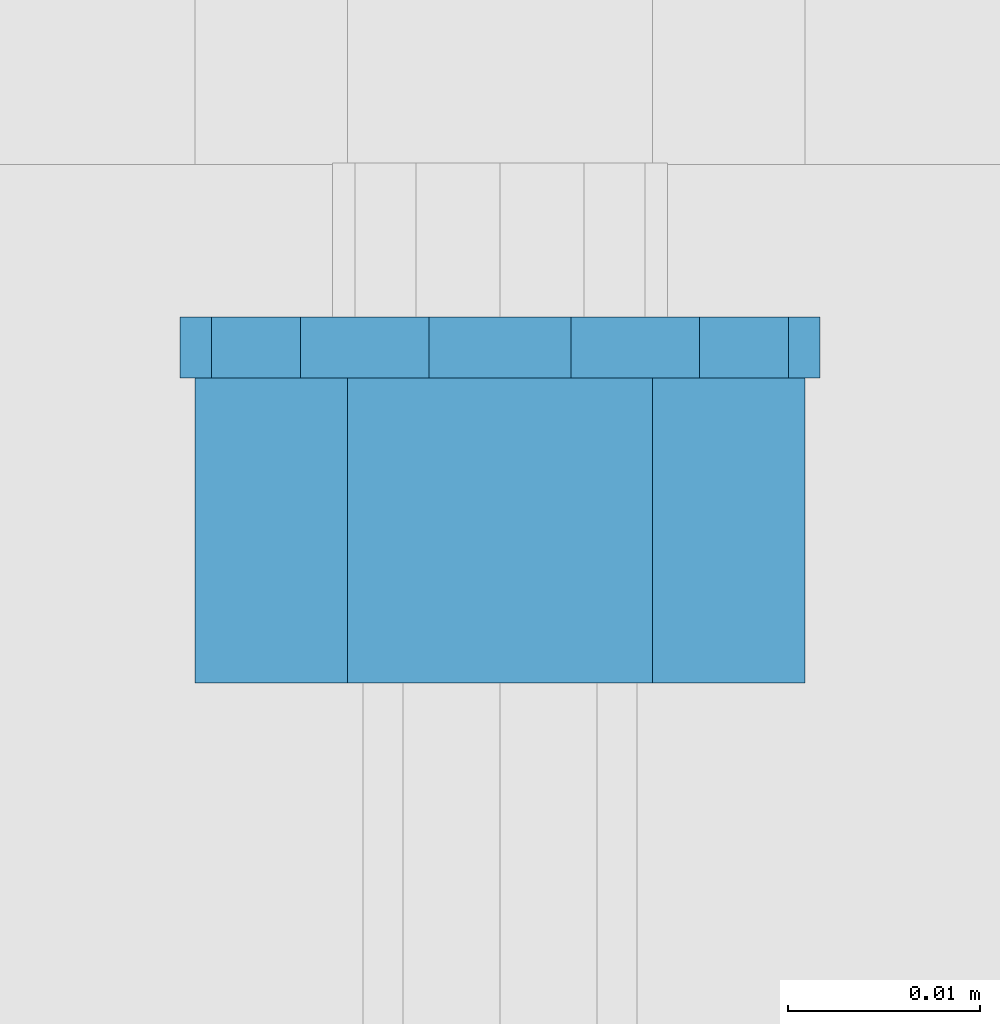
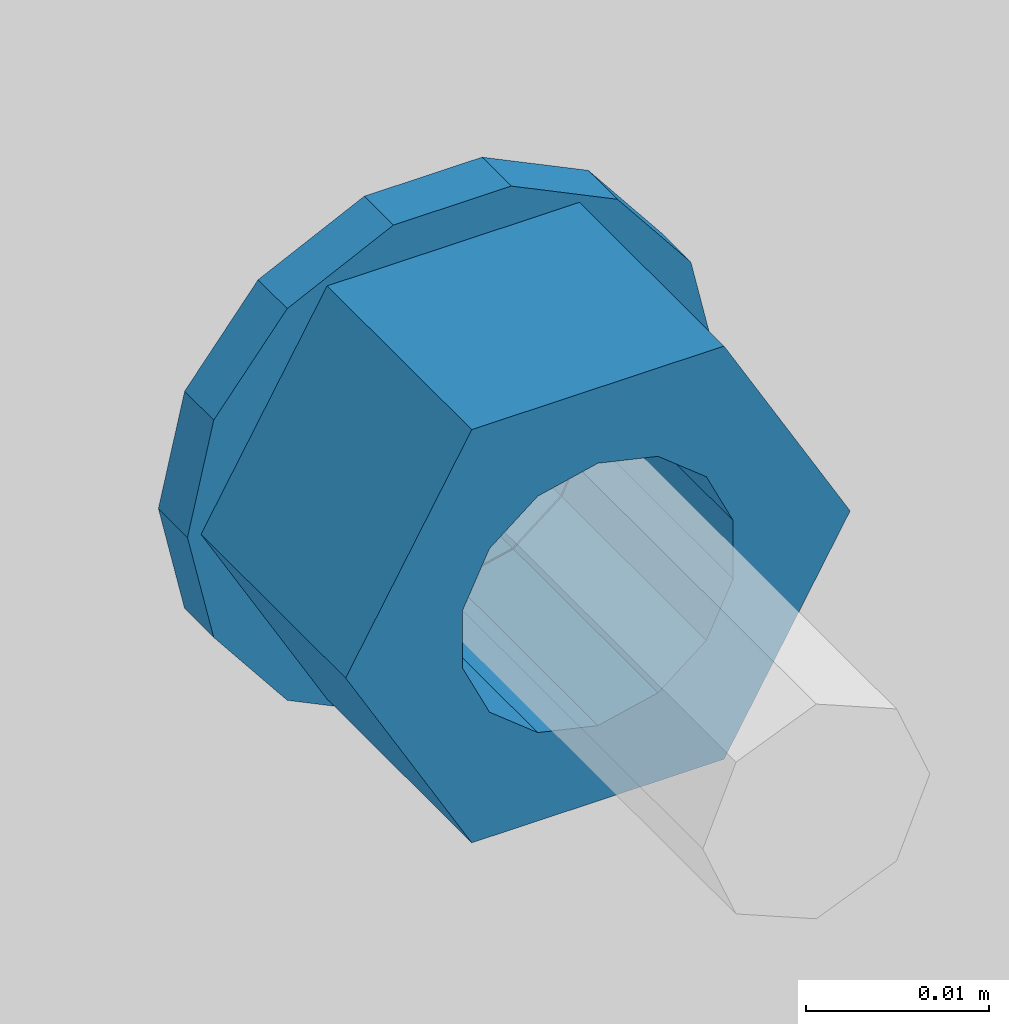
# One storey, part 613 of 975: 2 beams.
"""IFC2X3 building model written with IfcOpenShell, lengths in millimetres."""

from ifc_helpers import new_model, si_unit, frame, origin_with_axes, place, context, subcontext, project, spatial, faceted_brep, material, type_object, element, save


model = new_model("IFC2X3")

# Units and contexts
model_context = context("Model", 3, precision=1e-05, world=origin_with_axes())
body_context = subcontext(model_context, "Body", "Model", "MODEL_VIEW")
ifc_project = project(units=[si_unit("LENGTHUNIT", "METRE", prefix="MILLI"), si_unit("AREAUNIT", "SQUARE_METRE"), si_unit("VOLUMEUNIT", "CUBIC_METRE"), si_unit("MASSUNIT", "GRAM", prefix="KILO"), si_unit("TIMEUNIT", "SECOND"), si_unit("PLANEANGLEUNIT", "RADIAN"), si_unit("SOLIDANGLEUNIT", "STERADIAN"), si_unit("THERMODYNAMICTEMPERATUREUNIT", "DEGREE_CELSIUS"), si_unit("LUMINOUSINTENSITYUNIT", "LUMEN")], contexts=[model_context])

# Site, building, storey
site_placement = place(None, origin_with_axes())
site = spatial("IfcSite", under=ifc_project, at=site_placement, CompositionType="ELEMENT")
building_placement = place(site_placement, origin_with_axes())
building = spatial("IfcBuilding", under=site, at=building_placement, Name="Undefined", CompositionType="ELEMENT")
storey_placement = place(building_placement, origin_with_axes())
storey = spatial("IfcBuildingStorey", under=building, at=storey_placement, Name="Undefined", CompositionType="ELEMENT", Elevation=0.0)

# Beams
ifc_material = material(Name="STEEL/A36")
beam_type_1 = type_object("IfcBeamType", Name="5/8_HEAVY_HEX_NUT", PredefinedType="NOTDEFINED")
beam_1_placement = place(storey_placement, frame((9848.84992675423, 20416.8375, 3886.2), z_axis=(0.0, 0.0, 1.0), x_axis=(0.0, 1.0, 0.0)))
element("IfcBeam", 1, at=beam_1_placement, inside=storey, type_object=beam_type_1, material=ifc_material, Name="NUT", ObjectType="5/8_HEAVY_HEX_NUT", context=body_context, shape_type="Brep", body=[
    faceted_brep([(-1.09139364212751e-11, -15.8800001144436, -2.72848410531878e-12), (1.45519152283669e-11, -7.94000005722046, -13.7500000000036), (15.8750000000146, -7.94000005722137, -13.7500000000045), (15.8749999999891, -15.8800001144446, -2.72848410531878e-12), (2.91038304567337e-11, 7.94000005722319, -13.7500000000027), (15.8750000000291, 7.94000005722319, -13.7500000000027), (2.18278728425503e-11, 15.8800001144436, 9.09494701772928e-13), (15.8750000000218, 15.8800001144427, 9.09494701772928e-13), (-7.27595761418343e-12, 7.94000005722046, 13.7500000000027), (15.8749999999927, 7.94000005722046, 13.7500000000027), (-2.18278728425503e-11, -7.94000005722228, 13.7500000000009), (15.8749999999782, -7.94000005722319, 13.7500000000009), (-7.27595761418343e-12, 0.0, 8.72999954223724), (0.0, 3.78780484388062, 7.86545780435881), (15.875, 3.78780484387971, 7.86545780435881), (15.8749999999927, -9.09494701772928e-13, 8.72999954223724), (7.27595761418343e-12, 6.82538848405238, 5.44306568481716), (15.8750000000073, 6.82538848405238, 5.44306568481716), (1.09139364212751e-11, 8.51112022706275, 1.94260765157742), (15.8750000000109, 8.51112022706093, 1.94260765157651), (1.45519152283669e-11, 8.51112022706184, -1.94260765157651), (15.8750000000146, 8.51112022706184, -1.94260765157651), (2.18278728425503e-11, 6.8253884840542, -5.44306568481716), (15.8750000000218, 6.82538848405238, -5.44306568481716), (1.81898940354586e-11, 3.78780484388153, -7.86545780435881), (15.8750000000182, 3.78780484388062, -7.86545780435881), (1.81898940354586e-11, 9.09494701772928e-13, -8.72999954223997), (15.8750000000182, 9.09494701772928e-13, -8.72999954223997), (1.09139364212751e-11, -3.78780484387971, -7.86545780436063), (15.8750000000109, -3.78780484388062, -7.86545780436063), (3.63797880709171e-12, -6.82538848405238, -5.44306568481807), (15.8750000000036, -6.82538848405329, -5.44306568481807), (0.0, -8.51112022706184, -1.94260765157833), (15.875, -8.51112022706184, -1.94260765157833), (-7.27595761418343e-12, -8.51112022706184, 1.9426076515756), (15.8749999999927, -8.51112022706275, 1.9426076515756), (-1.09139364212751e-11, -6.82538848405329, 5.44306568481534), (15.8749999999927, -6.8253884840542, 5.44306568481534), (-7.27595761418343e-12, -3.78780484388062, 7.8654578043579), (15.8749999999927, -3.78780484388153, 7.8654578043579)], [[[0, 1, 2, 3]], [[1, 4, 5, 2]], [[4, 6, 7, 5]], [[6, 8, 9, 7]], [[8, 10, 11, 9]], [[10, 0, 3, 11]], [[12, 13, 14, 15]], [[13, 16, 17, 14]], [[16, 18, 19, 17]], [[18, 20, 21, 19]], [[20, 22, 23, 21]], [[22, 24, 25, 23]], [[24, 26, 27, 25]], [[26, 28, 29, 27]], [[28, 30, 31, 29]], [[30, 32, 33, 31]], [[32, 34, 35, 33]], [[34, 36, 37, 35]], [[36, 38, 39, 37]], [[38, 12, 15, 39]], [[5, 7, 9, 11, 3, 2], [17, 19, 21, 23, 25, 27, 29, 31, 33, 35, 37, 39, 15, 14]], [[10, 8, 6, 4, 1, 0], [38, 36, 34, 32, 30, 28, 26, 24, 22, 20, 18, 16, 13, 12]]]),
])
beam_type_2 = type_object("IfcBeamType", Name="5/8_WASHER", PredefinedType="NOTDEFINED")
beam_2_placement = place(storey_placement, frame((9848.84992675424, 20432.7125, 3886.2), z_axis=(0.0, 0.0, 1.0), x_axis=(0.0, 1.0, 0.0)))
element("IfcBeam", 2, at=beam_2_placement, inside=storey, type_object=beam_type_2, material=ifc_material, Name="WASHER", ObjectType="5/8_WASHER", context=body_context, shape_type="Brep", body=[
    faceted_brep([(1.09139364212751e-11, -16.670000076293, -2.72848410531878e-12), (2.18278728425503e-11, -15.0191510966704, -7.23284196419536), (3.1750000000211, -15.0191510966711, -7.23284196419627), (3.17500000001019, -16.6700000762937, -1.81898940354586e-12), (2.91038304567337e-11, -10.3935750445523, -13.0331308723944), (3.17500000002838, -10.3935750445526, -13.0331308723953), (2.91038304567337e-11, -3.70942398602756, -16.2520483704566), (3.17500000002838, -3.70942398602779, -16.2520483704566), (2.5465851649642e-11, 3.70942398602961, -16.2520483704557), (3.17500000002474, 3.70942398602961, -16.2520483704566), (1.45519152283669e-11, 10.3935750445542, -13.0331308723935), (3.17500000001382, 10.3935750445537, -13.0331308723944), (0.0, 15.0191510966717, -7.23284196419354), (3.17499999999927, 15.0191510966713, -7.23284196419354), (-7.27595761418343e-12, 16.6700000762933, 0.0), (3.174999999992, 16.6700000762928, -9.09494701772928e-13), (-1.81898940354586e-11, 15.0191510966706, 7.23284196419354), (3.17499999998108, 15.0191510966704, 7.23284196419354), (-2.5465851649642e-11, 10.3935750445519, 13.0331308723926), (3.17499999997381, 10.3935750445517, 13.0331308723926), (-2.5465851649642e-11, 3.70942398602733, 16.2520483704538), (3.17499999997381, 3.7094239860271, 16.2520483704529), (-2.18278728425503e-11, -3.70942398602983, 16.2520483704529), (3.17499999997744, -3.70942398603006, 16.2520483704538), (-1.09139364212751e-11, -10.3935750445542, 13.0331308723908), (3.17499999998836, -10.3935750445544, 13.0331308723908), (0.0, -15.0191510966717, 7.23284196419172), (3.17499999999927, -15.019151096672, 7.23284196419081), (-7.27595761418343e-12, 0.0, 8.72999954223724), (0.0, 3.78780484388062, 7.86545780435881), (3.17499999998472, 3.78780484387903, 7.86545780435699), (3.17499999998836, -9.09494701772928e-13, 8.72999954223542), (7.27595761418343e-12, 6.82538848405238, 5.44306568481716), (3.17499999998836, 6.82538848405102, 5.44306568481534), (1.09139364212751e-11, 8.51112022706275, 1.94260765157742), (3.174999999992, 8.51112022705979, 1.94260765157651), (1.45519152283669e-11, 8.51112022706184, -1.94260765157651), (3.17499999999563, 8.51112022706025, -1.94260765157742), (2.18278728425503e-11, 6.8253884840542, -5.44306568481716), (3.17500000000655, 6.8253884840517, -5.44306568481807), (1.81898940354586e-11, 3.78780484388153, -7.86545780435881), (3.17500000001019, 3.78780484388017, -7.86545780435972), (1.81898940354586e-11, 9.09494701772928e-13, -8.72999954223997), (3.17500000001382, 6.82121026329696e-13, -8.72999954223997), (1.09139364212751e-11, -3.78780484387971, -7.86545780436063), (3.17500000001382, -3.78780484387994, -7.86545780436063), (3.63797880709171e-12, -6.82538848405238, -5.44306568481807), (3.17500000001019, -6.82538848405147, -5.44306568481898), (0.0, -8.51112022706184, -1.94260765157833), (3.17500000001019, -8.5111202270607, -1.94260765157924), (-7.27595761418343e-12, -8.51112022706184, 1.9426076515756), (3.17500000000291, -8.51112022706093, 1.94260765157469), (-1.09139364212751e-11, -6.82538848405329, 5.44306568481534), (3.17499999999563, -6.82538848405238, 5.44306568481534), (-7.27595761418343e-12, -3.78780484388062, 7.8654578043579), (3.174999999992, -3.78780484388085, 7.86545780435699)], [[[0, 1, 2, 3]], [[1, 4, 5, 2]], [[4, 6, 7, 5]], [[6, 8, 9, 7]], [[8, 10, 11, 9]], [[10, 12, 13, 11]], [[12, 14, 15, 13]], [[14, 16, 17, 15]], [[16, 18, 19, 17]], [[18, 20, 21, 19]], [[20, 22, 23, 21]], [[22, 24, 25, 23]], [[24, 26, 27, 25]], [[26, 0, 3, 27]], [[28, 29, 30, 31]], [[29, 32, 33, 30]], [[32, 34, 35, 33]], [[34, 36, 37, 35]], [[36, 38, 39, 37]], [[38, 40, 41, 39]], [[40, 42, 43, 41]], [[42, 44, 45, 43]], [[44, 46, 47, 45]], [[46, 48, 49, 47]], [[48, 50, 51, 49]], [[50, 52, 53, 51]], [[52, 54, 55, 53]], [[54, 28, 31, 55]], [[5, 7, 9, 11, 13, 15, 17, 19, 21, 23, 25, 27, 3, 2], [33, 35, 37, 39, 41, 43, 45, 47, 49, 51, 53, 55, 31, 30]], [[26, 24, 22, 20, 18, 16, 14, 12, 10, 8, 6, 4, 1, 0], [54, 52, 50, 48, 46, 44, 42, 40, 38, 36, 34, 32, 29, 28]]]),
])

save(model, "model.ifc")
